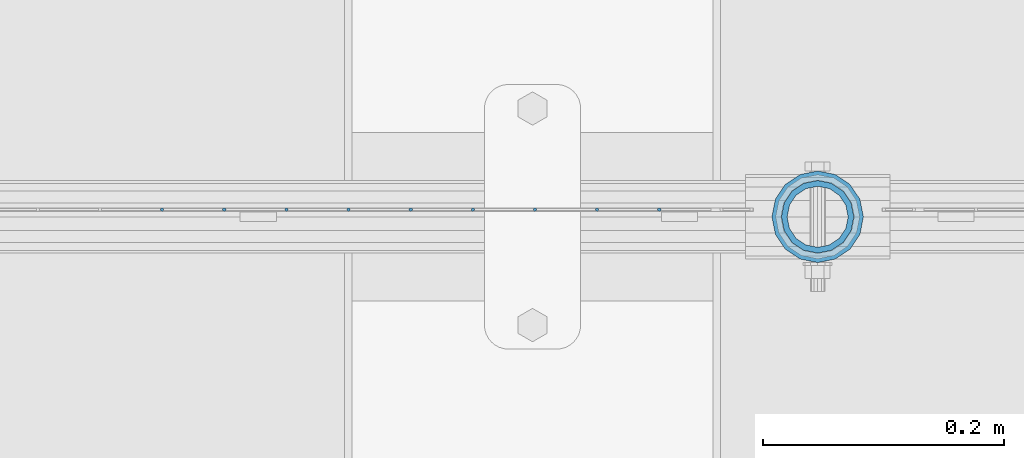
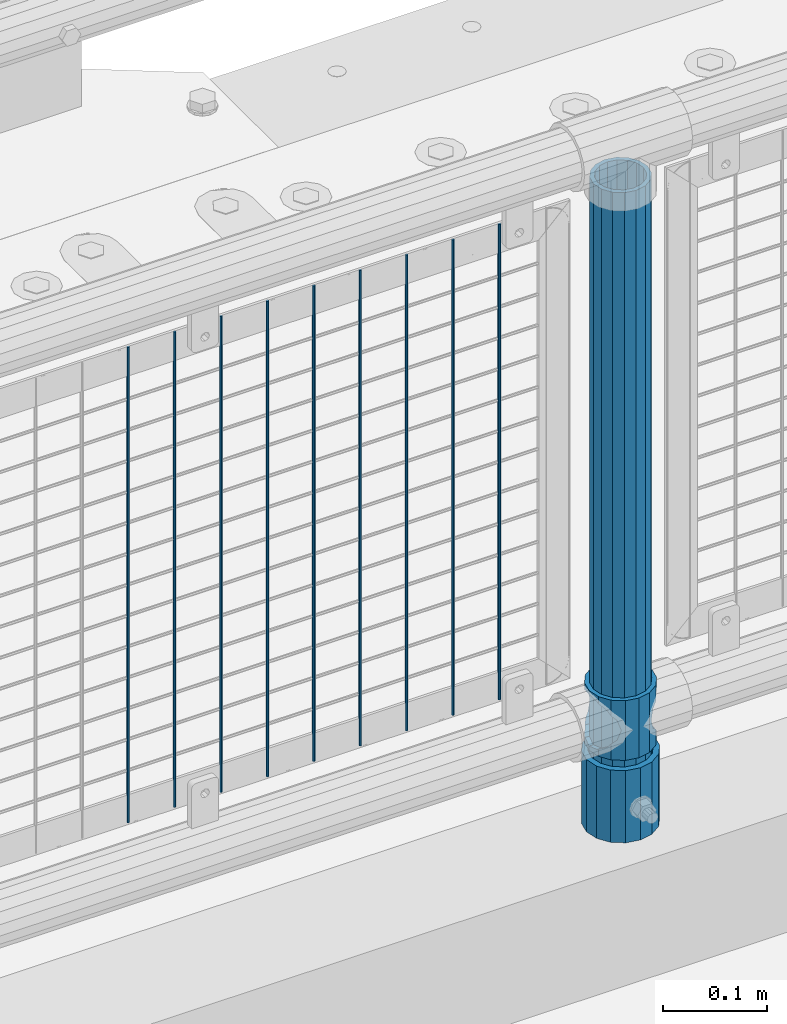
# One storey, part 58 of 193: 12 columns.
"""IFC2X3 building model written with IfcOpenShell, lengths in millimetres."""

import ifcopenshell
import ifcopenshell.guid

model = None  # the IFC model being written
_history = None  # IfcOwnerHistory: only IFC2X3 demands one
_inside = {}  # id of a spatial element -> (the spatial element, [elements in it])
_under = {}  # id of a project, library or spatial element -> (it, [spatial elements below it])
_declared = {}  # id of a project -> (the project, [libraries it declares])
_typed = {}  # id of a type object -> (the type object, [elements of that type])
_made_of = {}  # id of a material, layer set ... -> (it, [elements and type objects made of it])


def new_model(schema):
    """Start an empty IFC model of exactly this schema.

    Asked for "IFC4X3", IfcOpenShell would pick the latest addendum, in which some entities
    have other attributes; the version numbers below select the first issue.
    IFC2X3 requires an IfcOwnerHistory on every rooted entity: one is made here for all.
    """
    global model, _history
    if schema == "IFC4X3":
        model = ifcopenshell.file(schema_version=(4, 3, 0, 0))
    else:
        model = ifcopenshell.file(schema=schema)
    _inside.clear()
    _under.clear()
    _declared.clear()
    _typed.clear()
    _made_of.clear()
    _history = None
    if model.schema == "IFC2X3":
        org = make("IfcOrganization", Name="unknown")
        user = make(
            "IfcPersonAndOrganization",
            ThePerson=make("IfcPerson", FamilyName="unknown"),
            TheOrganization=org,
        )
        app = make(
            "IfcApplication",
            ApplicationDeveloper=org,
            Version="unknown",
            ApplicationFullName="unknown",
            ApplicationIdentifier="unknown",
        )
        _history = make(
            "IfcOwnerHistory",
            OwningUser=user,
            OwningApplication=app,
            ChangeAction="ADDED",
            CreationDate=0,
        )
    return model


def make(cls, **values):
    """One entity of the class cls with the attributes given. An attribute that is None is left unset."""
    return model.create_entity(
        cls, **{name: value for name, value in values.items() if value is not None}
    )


def rooted(cls, **values):
    """An entity with a GlobalId (a new one), such as an element, a storey or a relation."""
    return make(cls, GlobalId=ifcopenshell.guid.new(), OwnerHistory=_history, **values)


def si_unit(unit_type, name, prefix=None):
    """IfcSIUnit, for example si_unit("LENGTHUNIT", "METRE", prefix="MILLI")."""
    return make("IfcSIUnit", UnitType=unit_type, Prefix=prefix, Name=name)


def assignment(units):
    """IfcUnitAssignment: the units of a project."""
    return None if units is None else make("IfcUnitAssignment", Units=units)


def point(xyz):
    """IfcCartesianPoint."""
    return None if xyz is None else make("IfcCartesianPoint", Coordinates=xyz)


def direction(xyz):
    """IfcDirection."""
    return None if xyz is None else make("IfcDirection", DirectionRatios=xyz)


def frame(location, z_axis=None, x_axis=None):
    """IfcAxis2Placement3D, a coordinate frame: its origin and axes. An axis left out is left unset."""
    return make(
        "IfcAxis2Placement3D",
        Location=point(location),
        Axis=direction(z_axis),
        RefDirection=direction(x_axis),
    )


def origin_with_axes():
    """The frame at (0, 0, 0) with the z axis (0, 0, 1) and the x axis (1, 0, 0) written out."""
    return frame((0.0, 0.0, 0.0), z_axis=(0.0, 0.0, 1.0), x_axis=(1.0, 0.0, 0.0))


def place(relative_to, where):
    """IfcLocalPlacement: puts the frame where relative to a parent placement (None: the world)."""
    return make(
        "IfcLocalPlacement", PlacementRelTo=relative_to, RelativePlacement=where
    )


def context(
    kind, dimensions, precision=None, world=None, true_north=None, identifier=None
):
    """IfcGeometricRepresentationContext, for example the 3D "Model" context."""
    return make(
        "IfcGeometricRepresentationContext",
        ContextIdentifier=identifier,
        ContextType=kind,
        CoordinateSpaceDimension=dimensions,
        Precision=precision,
        WorldCoordinateSystem=world,
        TrueNorth=true_north,
    )


def subcontext(parent, identifier, kind, view, scale=None):
    """IfcGeometricRepresentationSubContext, for example "Body" below "Model"."""
    return make(
        "IfcGeometricRepresentationSubContext",
        ContextIdentifier=identifier,
        ContextType=kind,
        ParentContext=parent,
        TargetScale=scale,
        TargetView=view,
    )


def project(units=None, contexts=None):
    """IfcProject with its units and contexts."""
    return rooted(
        "IfcProject",
        Name="project",
        RepresentationContexts=contexts,
        UnitsInContext=assignment(units),
    )


def spatial(cls, under=None, at=None, **own):
    """A site, building, storey or space (cls), placed at a placement, below another one or the project."""
    s = rooted(cls, ObjectPlacement=at, **own)
    if under is not None:
        _under.setdefault(under.id(), (under, []))[1].append(s)
    return s


def faces_of(points, faces, orient=None, outer=None):
    """IfcFace entities. A face is a list of loops; a loop is a list of indices into points, from 0.

    orient and outer hold one flag for each loop. By default every Orientation is true, the
    first loop of a face is its IfcFaceOuterBound and the others are IfcFaceBound.
    """
    made = []
    for i, loops in enumerate(faces):
        bounds = []
        for j, loop in enumerate(loops):
            is_outer = j == 0 if outer is None else outer[i][j]
            bounds.append(
                make(
                    "IfcFaceOuterBound" if is_outer else "IfcFaceBound",
                    Bound=make("IfcPolyLoop", Polygon=[points[k] for k in loop]),
                    Orientation=True if orient is None else orient[i][j],
                )
            )
        made.append(make("IfcFace", Bounds=bounds))
    return made


def faceted_brep(points, faces, orient=None, outer=None, voids=None):
    """IfcFacetedBrep: a solid bounded by flat faces; with voids (closed shells), ...WithVoids."""
    shared = [point(p) for p in points]
    hull = make("IfcClosedShell", CfsFaces=faces_of(shared, faces, orient, outer))
    if voids is None:
        return make("IfcFacetedBrep", Outer=hull)
    return make(
        "IfcFacetedBrepWithVoids",
        Outer=hull,
        Voids=[
            make(cls, CfsFaces=faces_of(shared, fs, o, b)) for cls, fs, o, b in voids
        ],
    )


def shape(context_of_items, identifier, shape_type, items):
    """IfcShapeRepresentation: the items that make up one representation, for example the "Body"."""
    return make(
        "IfcShapeRepresentation",
        ContextOfItems=context_of_items,
        RepresentationIdentifier=identifier,
        RepresentationType=shape_type,
        Items=items,
    )


def material(Name=None, Category=None):
    """IfcMaterial."""
    return make("IfcMaterial", Name=Name, Category=Category)


def made_of(thing, what):
    """Note that an element or type object is made of a material, layer set ...; save() writes the relation."""
    if what is not None:
        _made_of.setdefault(what.id(), (what, []))[1].append(thing)
    return thing


def type_object(cls, material=None, **own):
    """A type object (cls), such as IfcWallType, which elements share."""
    return made_of(rooted(cls, **own), material)


def element(
    cls,
    number,
    at=None,
    inside=None,
    cuts=None,
    type_object=None,
    material=None,
    context=None,
    identifier="Body",
    shape_type=None,
    held_by="IfcProductDefinitionShape",
    body=None,
    shapes=None,
    **own,
):
    """One element of the class cls, such as IfcWall. Its Tag is "e" and its number.

    at: its placement. inside: the storey or other place that contains it. cuts: it is an
    opening in that element (IfcRelVoidsElement). A single representation is given by context,
    identifier, shape_type and body (its items); several are given by shapes. held_by: the class
    of the entity that holds the representations. save() writes the other relations.
    """
    e = rooted(cls, Tag="e%d" % number, ObjectPlacement=at, **own)
    if body is not None:
        shapes = [shape(context, identifier, shape_type, body)]
    if shapes is not None:
        e.Representation = make(held_by, Representations=shapes)
    if inside is not None:
        _inside.setdefault(inside.id(), (inside, []))[1].append(e)
    if cuts is not None:
        rooted(
            "IfcRelVoidsElement", RelatingBuildingElement=cuts, RelatedOpeningElement=e
        )
    if type_object is not None:
        _typed.setdefault(type_object.id(), (type_object, []))[1].append(e)
    return made_of(e, material)


def aggregate(whole, parts):
    """IfcRelAggregates: a whole, such as a stair, and the parts it consists of."""
    return rooted("IfcRelAggregates", RelatingObject=whole, RelatedObjects=parts)


def save(model, path):
    """Write the relations noted so far, then the file.

    IfcRelAggregates (storeys below a building ...), IfcRelContainedInSpatialStructure (elements
    in a storey), IfcRelDefinesByType, IfcRelAssociatesMaterial and IfcRelDeclares: one each for
    every whole, place, type object, material and project.
    """
    for whole, parts in _under.values():
        aggregate(whole, parts)
    for where, things in _inside.values():
        rooted(
            "IfcRelContainedInSpatialStructure",
            RelatedElements=things,
            RelatingStructure=where,
        )
    for kind, things in _typed.values():
        rooted("IfcRelDefinesByType", RelatedObjects=things, RelatingType=kind)
    for what, things in _made_of.values():
        rooted("IfcRelAssociatesMaterial", RelatedObjects=things, RelatingMaterial=what)
    for by, libraries in _declared.values():
        rooted("IfcRelDeclares", RelatingContext=by, RelatedDefinitions=libraries)
    model.write(path)


model = new_model("IFC2X3")

# Units and contexts
model_context = context("Model", 3, precision=1e-05, world=origin_with_axes())
body_context = subcontext(model_context, "Body", "Model", "MODEL_VIEW")
ifc_project = project(units=[si_unit("LENGTHUNIT", "METRE", prefix="MILLI"), si_unit("AREAUNIT", "SQUARE_METRE"), si_unit("VOLUMEUNIT", "CUBIC_METRE"), si_unit("MASSUNIT", "GRAM", prefix="KILO"), si_unit("TIMEUNIT", "SECOND"), si_unit("PLANEANGLEUNIT", "RADIAN"), si_unit("SOLIDANGLEUNIT", "STERADIAN"), si_unit("THERMODYNAMICTEMPERATUREUNIT", "DEGREE_CELSIUS"), si_unit("LUMINOUSINTENSITYUNIT", "LUMEN")], contexts=[model_context])

# Site, building, storey
site_placement = place(None, origin_with_axes())
site = spatial("IfcSite", under=ifc_project, at=site_placement, CompositionType="ELEMENT")
building_placement = place(site_placement, origin_with_axes())
building = spatial("IfcBuilding", under=site, at=building_placement, Name="Standard", CompositionType="ELEMENT")
storey_placement = place(building_placement, origin_with_axes())
storey = spatial("IfcBuildingStorey", under=building, at=storey_placement, Name="Undefined", CompositionType="ELEMENT", Elevation=0.0)

# Columns
ifc_material_1 = material(Name="Misc_Undefined")
column_type_1 = type_object("IfcColumnType", PredefinedType="NOTDEFINED")
column_1_placement = place(storey_placement, frame((-38513.0, 28664.5, 263.020000000001), z_axis=(-1.0, 0.0, 0.0), x_axis=(0.0, 0.0, 1.0)))
element("IfcColumn", 1, at=column_1_placement, inside=storey, type_object=column_type_1, material=ifc_material_1, context=body_context, shape_type="Brep", body=[
    faceted_brep([(56.6106908090114, 21.46069080901, -21.46069080901), (56.6106908090114, 21.46069080901, -27.1226768591041), (61.9623795176744, 13.4513226476338, -32.4743655677703), (63.1897438117172, 11.614442172282, -32.8397438117245), (63.1897438117172, 11.614442172282, -28.0397438117179), (46.7644421722801, 28.0397438117179, -11.614442172282), (46.7644421722801, 28.0397438117179, -20.0882031229849), (51.5310424080006, 24.8548033587067, -24.8548033587067), (35.1500000000015, 30.35, 0.0), (35.1499999999996, 30.3499999999985, -16.6306603983685), (23.5355578277192, 28.0397438117179, -11.614442172282), (23.5355578277192, 28.0397438117179, -20.0882031229849), (13.6893091909879, 21.46069080901, -21.46069080901), (13.6893091909879, 21.46069080901, -27.1226768591041), (18.7689575919987, 24.8548033587067, -24.8548033587067), (7.11025618828211, 11.614442172282, -28.0397438117179), (7.11025618828211, 11.614442172282, -32.8397438117245), (8.33762048232262, 13.4513226476338, -32.4743655677703), (4.79999999999961, 0.0, -30.3499999999985), (4.79999999999961, 0.0, -35.1500000000015), (7.11025618828211, -11.614442172282, -28.0397438117179), (7.11025618828211, -11.614442172282, -32.8397438117172), (13.6893091909879, -21.46069080901, -21.46069080901), (13.6893091909879, -21.46069080901, -27.1226768591114), (8.33762048232484, -13.4513226476338, -32.4743655677703), (23.5355578277191, -28.0397438117179, -11.614442172282), (23.5355578277191, -28.0397438117179, -20.0882031229812), (18.7689575919921, -24.8548033587067, -24.8548033587067), (35.1500000000015, -30.35, 0.0), (35.1499999999996, -30.3499999999985, -16.6306603983721), (46.7644421722801, -28.0397438117179, -11.614442172282), (46.7644421722801, -28.0397438117179, -20.0882031229812), (56.6106908090114, -21.46069080901, -21.46069080901), (56.6106908090114, -21.46069080901, -27.1226768591114), (51.5310424080006, -24.8548033587067, -24.8548033587067), (63.1897438117172, -11.614442172282, -28.0397438117179), (63.1897438117172, -11.614442172282, -32.8397438117172), (61.9623795176767, -13.4513226476338, -32.4743655677703), (65.4999999999997, 0.0, -30.3499999999985), (65.4999999999997, 0.0, -35.1500000000015), (0.0, -28.0397438117179, -11.614442172282), (0.0, -30.3499999999985, 0.0), (0.0, -21.46069080901, -21.46069080901), (0.0, -11.614442172282, -28.0397438117179), (0.0, 0.0, -30.3499999999985), (0.0, 11.614442172282, -28.0397438117179), (0.0, 21.46069080901, -21.46069080901), (0.0, 28.0397438117179, -11.614442172282), (0.0, 30.3499999999985, 0.0), (0.0, 28.0397438117179, 11.614442172282), (23.5355578277192, 28.0397438117179, 11.614442172282), (0.0, 21.46069080901, 21.46069080901), (13.6893091909879, 21.46069080901, 21.46069080901), (0.0, 11.614442172282, 28.0397438117179), (7.11025618828211, 11.614442172282, 28.0397438117179), (0.0, 0.0, 30.3499999999985), (4.79999999999961, 0.0, 30.3499999999985), (0.0, -11.614442172282, 28.0397438117179), (7.11025618828205, -11.614442172282, 28.0397438117179), (0.0, -21.46069080901, 21.46069080901), (13.6893091909879, -21.46069080901, 21.46069080901), (0.0, -28.0397438117179, 11.614442172282), (23.5355578277191, -28.0397438117179, 11.614442172282), (0.0, -32.4743655677703, 13.4513226476338), (0.0, -35.1500000000015, 0.0), (70.2999999999993, -35.1500000000015, 0.0), (70.2999999999993, -32.4743655677703, 13.4513226476338), (0.0, 13.4513226476338, -32.4743655677703), (0.0, 24.8548033587067, -24.8548033587067), (0.0, 0.0, -35.1500000000015), (0.0, -13.4513226476338, -32.4743655677703), (0.0, -24.8548033587067, -24.8548033587067), (0.0, -24.8548033587067, 24.8548033587067), (0.0, -13.4513226476338, 32.4743655677703), (0.0, 0.0, 35.1500000000015), (0.0, 13.4513226476338, 32.4743655677703), (0.0, 24.8548033587067, 24.8548033587067), (0.0, 32.4743655677703, 13.4513226476338), (0.0, 35.1500000000015, 0.0), (0.0, 32.4743655677703, -13.4513226476338), (0.0, -32.4743655677703, -13.4513226476338), (70.2999999999993, 32.4743655677703, 13.4513226476338), (70.2999999999993, 35.1500000000015, 0.0), (70.2999999999993, 32.4743655677703, -13.4513226476338), (70.2999999999993, 24.8548033587067, -24.8548033587067), (70.2999999999993, 13.4513226476338, -32.4743655677703), (70.2999999999993, 0.0, -35.1500000000015), (70.2999999999993, -13.4513226476338, -32.4743655677703), (70.2999999999993, -24.8548033587067, -24.8548033587067), (70.2999999999993, -32.4743655677703, -13.4513226476338), (70.2999999999993, 28.0397438117179, 11.614442172282), (70.2999999999993, 21.46069080901, 21.46069080901), (56.6106908090114, 21.46069080901, 21.46069080901), (46.7644421722801, 28.0397438117179, 11.614442172282), (70.2999999999993, 11.614442172282, 28.0397438117179), (63.1897438117172, 11.614442172282, 28.0397438117179), (70.2999999999993, 0.0, 30.3499999999985), (65.4999999999997, 0.0, 30.3499999999985), (70.2999999999993, -11.614442172282, 28.0397438117179), (63.1897438117172, -11.614442172282, 28.0397438117179), (70.2999999999993, -21.46069080901, 21.46069080901), (56.6106908090114, -21.46069080901, 21.46069080901), (70.2999999999993, -28.0397438117179, 11.614442172282), (46.7644421722801, -28.0397438117179, 11.614442172282), (70.2999999999993, -11.614442172282, -28.0397438117179), (70.2999999999993, 0.0, -30.3499999999985), (70.2999999999993, -21.46069080901, -21.46069080901), (70.2999999999993, -28.0397438117179, -11.614442172282), (70.2999999999993, -30.3499999999985, 0.0), (70.2999999999993, 24.8548033587067, 24.8548033587067), (70.2999999999993, 13.4513226476338, 32.4743655677703), (70.2999999999993, 0.0, 35.1500000000015), (70.2999999999993, -13.4513226476338, 32.4743655677703), (70.2999999999993, -24.8548033587067, 24.8548033587067), (70.2999999999993, 30.3499999999985, 0.0), (70.2999999999993, 28.0397438117179, -11.614442172282), (70.2999999999993, 21.46069080901, -21.46069080901), (70.2999999999993, 11.614442172282, -28.0397438117179), (61.9623795176742, 13.4513226476338, 32.4743655677703), (51.5310424080006, 24.8548033587067, 24.8548033587067), (56.6106908090114, 21.46069080901, 27.1226768591077), (65.4999999999997, 0.0, 35.1500000000015), (63.1897438117172, 11.614442172282, 32.8397438117136), (63.1897438117172, -11.614442172282, 32.8397438117136), (61.9623795176767, -13.4513226476338, 32.4743655677703), (56.6106908090114, -21.46069080901, 27.1226768591041), (51.5310424080006, -24.8548033587067, 24.8548033587067), (18.7689575919921, -24.8548033587067, 24.8548033587067), (46.7644421722801, -28.0397438117179, 20.0882031229812), (35.1499999999996, -30.3499999999985, 16.6306603983685), (23.5355578277191, -28.0397438117179, 20.0882031229812), (8.33762048232512, -13.4513226476338, 32.4743655677703), (13.6893091909879, -21.46069080901, 27.1226768591041), (4.79999999999961, 0.0, 35.1500000000015), (7.11025618828205, -11.614442172282, 32.8397438117136), (7.11025618828211, 11.614442172282, 32.8397438117136), (8.3376204823229, 13.4513226476338, 32.4743655677703), (13.6893091909879, 21.46069080901, 27.1226768591077), (18.7689575919987, 24.8548033587067, 24.8548033587067), (23.5355578277192, 28.0397438117179, 20.0882031229739), (35.1499999999996, 30.3499999999985, 16.6306603983576), (46.7644421722801, 28.0397438117179, 20.0882031229739)], [[[0, 1, 2, 3, 4]], [[5, 6, 7, 1, 0]], [[8, 9, 6, 5]], [[10, 11, 9, 8]], [[12, 13, 14, 11, 10]], [[15, 16, 17, 13, 12]], [[18, 19, 16, 15]], [[20, 21, 19, 18]], [[22, 23, 24, 21, 20]], [[25, 26, 27, 23, 22]], [[28, 29, 26, 25]], [[30, 31, 29, 28]], [[32, 33, 34, 31, 30]], [[35, 36, 37, 33, 32]], [[38, 39, 36, 35]], [[4, 3, 39, 38]], [[40, 41, 28, 25]], [[42, 40, 25, 22]], [[43, 42, 22, 20]], [[44, 43, 20, 18]], [[45, 44, 18, 15]], [[46, 45, 15, 12]], [[47, 46, 12, 10]], [[48, 47, 10, 8]], [[49, 48, 8, 50]], [[51, 49, 50, 52]], [[53, 51, 52, 54]], [[55, 53, 54, 56]], [[57, 55, 56, 58]], [[59, 57, 58, 60]], [[61, 59, 60, 62]], [[41, 61, 62, 28]], [[63, 64, 65, 66]], [[17, 67, 68, 14, 13]], [[19, 69, 67, 17, 16]], [[70, 69, 19, 21, 24]], [[71, 70, 24, 23, 27]], [[63, 72, 73, 74, 75, 76, 77, 78, 79, 68, 67, 69, 70, 71, 80, 64], [40, 42, 43, 44, 45, 46, 47, 48, 49, 51, 53, 55, 57, 59, 61, 41]], [[78, 77, 81, 82]], [[79, 78, 82, 83]], [[14, 68, 79, 83, 84, 7, 6, 9, 11]], [[84, 85, 2, 1, 7]], [[85, 86, 39, 3, 2]], [[37, 87, 88, 34, 33]], [[39, 86, 87, 37, 36]], [[34, 88, 89, 80, 71, 27, 26, 29, 31]], [[64, 80, 89, 65]], [[90, 91, 92, 93]], [[91, 94, 95, 92]], [[94, 96, 97, 95]], [[96, 98, 99, 97]], [[98, 100, 101, 99]], [[100, 102, 103, 101]], [[104, 105, 38, 35]], [[106, 104, 35, 32]], [[107, 106, 32, 30]], [[108, 107, 30, 28]], [[102, 108, 28, 103]], [[88, 87, 86, 85, 84, 83, 82, 81, 109, 110, 111, 112, 113, 66, 65, 89], [100, 98, 96, 94, 91, 90, 114, 115, 116, 117, 105, 104, 106, 107, 108, 102]], [[118, 110, 109, 119, 120]], [[121, 111, 110, 118, 122]], [[112, 111, 121, 123, 124]], [[113, 112, 124, 125, 126]], [[127, 72, 63, 66, 113, 126, 128, 129, 130]], [[131, 73, 72, 127, 132]], [[133, 74, 73, 131, 134]], [[75, 74, 133, 135, 136]], [[76, 75, 136, 137, 138]], [[119, 109, 81, 77, 76, 138, 139, 140, 141]], [[92, 120, 119, 141, 93]], [[95, 122, 118, 120, 92]], [[97, 121, 122, 95]], [[99, 123, 121, 97]], [[101, 125, 124, 123, 99]], [[103, 128, 126, 125, 101]], [[28, 129, 128, 103]], [[62, 130, 129, 28]], [[60, 132, 127, 130, 62]], [[58, 134, 131, 132, 60]], [[56, 133, 134, 58]], [[54, 135, 133, 56]], [[52, 137, 136, 135, 54]], [[50, 139, 138, 137, 52]], [[8, 140, 139, 50]], [[93, 141, 140, 8]], [[114, 90, 93, 8]], [[115, 114, 8, 5]], [[116, 115, 5, 0]], [[117, 116, 0, 4]], [[105, 117, 4, 38]]]),
])
ifc_material_2 = material()
column_type_2 = type_object("IfcColumnType", PredefinedType="NOTDEFINED")
column_2_placement = place(storey_placement, frame((-38513.0, 28664.5, 168.02), z_axis=(-1.0, 0.0, 0.0), x_axis=(0.0, 0.0, 1.0)))
element("IfcColumn", 2, at=column_2_placement, inside=storey, type_object=column_type_2, material=ifc_material_2, context=body_context, shape_type="Brep", body=[
    faceted_brep([(0.0, -25.3499999999985, 0.0), (0.0, -23.4203461491597, 9.70102501045403), (760.0, -23.4203461491597, 9.70102501045403), (760.0, -25.3499999999985, 0.0), (0.0, -17.9251569030785, 17.9251569030785), (760.0, -17.9251569030785, 17.9251569030785), (0.0, -9.70102501045403, 23.4203461491597), (760.0, -9.70102501045403, 23.4203461491597), (0.0, 0.0, 25.3499999999985), (760.0, 0.0, 25.3499999999985), (0.0, 9.70102501045403, 23.4203461491597), (760.0, 9.70102501045403, 23.4203461491597), (0.0, 17.9251569030785, 17.9251569030785), (760.0, 17.9251569030785, 17.9251569030785), (0.0, 23.4203461491597, 9.70102501045403), (760.0, 23.4203461491597, 9.70102501045403), (0.0, 25.3499999999985, 0.0), (760.0, 25.3499999999985, 0.0), (0.0, 23.4203461491597, -9.70102501045403), (760.0, 23.4203461491597, -9.70102501045403), (0.0, 17.9251569030785, -17.9251569030785), (760.0, 17.9251569030785, -17.9251569030785), (0.0, 9.70102501045403, -23.4203461491597), (760.0, 9.70102501045403, -23.4203461491597), (0.0, 0.0, -25.3499999999985), (760.0, 0.0, -25.3499999999985), (0.0, -9.70102501045403, -23.4203461491597), (760.0, -9.70102501045403, -23.4203461491597), (0.0, -17.9251569030785, -17.9251569030785), (760.0, -17.9251569030785, -17.9251569030785), (0.0, -23.4203461491597, -9.70102501045403), (760.0, -23.4203461491597, -9.70102501045403), (0.0, -30.1500000000015, 0.0), (0.0, -27.8549679052157, -11.5379054858058), (760.0, -27.8549679052157, -11.5379054858058), (760.0, -30.1500000000015, 0.0), (0.0, -21.3192694527752, -21.3192694527752), (760.0, -21.3192694527752, -21.3192694527752), (0.0, -11.5379054858058, -27.8549679052157), (760.0, -11.5379054858058, -27.8549679052157), (0.0, 0.0, -30.1500000000015), (760.0, 0.0, -30.1500000000015), (0.0, 11.5379054858058, -27.8549679052157), (760.0, 11.5379054858058, -27.8549679052157), (0.0, 21.3192694527752, -21.3192694527752), (760.0, 21.3192694527752, -21.3192694527752), (0.0, 27.8549679052157, -11.5379054858058), (760.0, 27.8549679052157, -11.5379054858058), (0.0, 30.1500000000015, 0.0), (760.0, 30.1500000000015, 0.0), (0.0, 27.8549679052157, 11.5379054858058), (760.0, 27.8549679052157, 11.5379054858058), (0.0, 21.3192694527752, 21.3192694527752), (760.0, 21.3192694527752, 21.3192694527752), (0.0, 11.5379054858058, 27.8549679052157), (760.0, 11.5379054858058, 27.8549679052157), (0.0, 0.0, 30.1500000000015), (760.0, 0.0, 30.1500000000015), (0.0, -11.5379054858058, 27.8549679052157), (760.0, -11.5379054858058, 27.8549679052157), (0.0, -21.3192694527752, 21.3192694527752), (760.0, -21.3192694527752, 21.3192694527752), (0.0, -27.8549679052157, 11.5379054858058), (760.0, -27.8549679052157, 11.5379054858058)], [[[0, 1, 2, 3]], [[1, 4, 5, 2]], [[4, 6, 7, 5]], [[6, 8, 9, 7]], [[8, 10, 11, 9]], [[10, 12, 13, 11]], [[12, 14, 15, 13]], [[14, 16, 17, 15]], [[16, 18, 19, 17]], [[18, 20, 21, 19]], [[20, 22, 23, 21]], [[22, 24, 25, 23]], [[24, 26, 27, 25]], [[26, 28, 29, 27]], [[28, 30, 31, 29]], [[30, 0, 3, 31]], [[32, 33, 34, 35]], [[33, 36, 37, 34]], [[36, 38, 39, 37]], [[38, 40, 41, 39]], [[40, 42, 43, 41]], [[42, 44, 45, 43]], [[44, 46, 47, 45]], [[46, 48, 49, 47]], [[48, 50, 51, 49]], [[50, 52, 53, 51]], [[52, 54, 55, 53]], [[54, 56, 57, 55]], [[56, 58, 59, 57]], [[58, 60, 61, 59]], [[60, 62, 63, 61]], [[62, 32, 35, 63]], [[37, 39, 41, 43, 45, 47, 49, 51, 53, 55, 57, 59, 61, 63, 35, 34], [5, 7, 9, 11, 13, 15, 17, 19, 21, 23, 25, 27, 29, 31, 3, 2]], [[62, 60, 58, 56, 54, 52, 50, 48, 46, 44, 42, 40, 38, 36, 33, 32], [30, 28, 26, 24, 22, 20, 18, 16, 14, 12, 10, 8, 6, 4, 1, 0]]]),
])
column_type_3 = type_object("IfcColumnType", PredefinedType="NOTDEFINED")
column_3_placement = place(storey_placement, frame((-38513.0, 28664.5, 168.02), z_axis=(0.0, 1.0, 0.0), x_axis=(0.0, 0.0, 1.0)))
element("IfcColumn", 3, at=column_3_placement, inside=storey, type_object=column_type_3, material=ifc_material_2, context=body_context, shape_type="Brep", body=[
    faceted_brep([(0.0, -31.75, 0.0), (0.0, -29.3331751572332, 12.1501989775934), (85.0, -29.3331751572332, 12.1501989775934), (85.0, -31.75, 0.0), (0.0, -22.4506403026717, 22.4506403026717), (85.0, -22.4506403026717, 22.4506403026717), (0.0, -12.1501989775934, 29.3331751572332), (85.0, -12.1501989775934, 29.3331751572332), (0.0, 0.0, 31.75), (85.0, 0.0, 31.75), (0.0, 12.1501989775934, 29.3331751572332), (85.0, 12.1501989775934, 29.3331751572332), (0.0, 22.4506403026717, 22.4506403026717), (85.0, 22.4506403026717, 22.4506403026717), (0.0, 29.3331751572332, 12.1501989775934), (85.0, 29.3331751572332, 12.1501989775934), (0.0, 31.75, 0.0), (85.0, 31.75, 0.0), (0.0, 29.3331751572332, -12.1501989775934), (85.0, 29.3331751572332, -12.1501989775934), (0.0, 22.4506403026717, -22.4506403026717), (85.0, 22.4506403026717, -22.4506403026717), (0.0, 12.1501989775934, -29.3331751572332), (85.0, 12.1501989775934, -29.3331751572332), (0.0, 0.0, -31.75), (85.0, 0.0, -31.75), (0.0, -12.1501989775934, -29.3331751572332), (85.0, -12.1501989775934, -29.3331751572332), (0.0, -22.4506403026717, -22.4506403026717), (85.0, -22.4506403026717, -22.4506403026717), (0.0, -29.3331751572332, -12.1501989775934), (85.0, -29.3331751572332, -12.1501989775934), (0.0, -38.0499999999993, 0.0), (0.0, -35.1536162120537, -14.5611046014928), (85.0, -35.1536162120537, -14.5611046014928), (85.0, -38.0499999999993, 0.0), (0.0, -26.9054130241493, -26.9054130241493), (85.0, -26.9054130241493, -26.9054130241493), (0.0, -14.5611046014928, -35.1536162120537), (85.0, -14.5611046014928, -35.1536162120537), (0.0, 0.0, -38.0499999999993), (85.0, 0.0, -38.0499999999993), (0.0, 14.5611046014928, -35.1536162120537), (85.0, 14.5611046014928, -35.1536162120537), (0.0, 26.9054130241493, -26.9054130241493), (85.0, 26.9054130241493, -26.9054130241493), (0.0, 35.1536162120537, -14.5611046014928), (85.0, 35.1536162120537, -14.5611046014928), (0.0, 38.0499999999993, 0.0), (85.0, 38.0499999999993, 0.0), (0.0, 35.1536162120537, 14.5611046014928), (85.0, 35.1536162120537, 14.5611046014928), (0.0, 26.9054130241493, 26.9054130241493), (85.0, 26.9054130241493, 26.9054130241493), (0.0, 14.5611046014928, 35.1536162120537), (85.0, 14.5611046014928, 35.1536162120537), (0.0, 0.0, 38.0499999999993), (85.0, 0.0, 38.0499999999993), (0.0, -14.5611046014928, 35.1536162120537), (85.0, -14.5611046014928, 35.1536162120537), (0.0, -26.9054130241493, 26.9054130241493), (85.0, -26.9054130241493, 26.9054130241493), (0.0, -35.1536162120537, 14.5611046014928), (85.0, -35.1536162120537, 14.5611046014928)], [[[0, 1, 2, 3]], [[1, 4, 5, 2]], [[4, 6, 7, 5]], [[6, 8, 9, 7]], [[8, 10, 11, 9]], [[10, 12, 13, 11]], [[12, 14, 15, 13]], [[14, 16, 17, 15]], [[16, 18, 19, 17]], [[18, 20, 21, 19]], [[20, 22, 23, 21]], [[22, 24, 25, 23]], [[24, 26, 27, 25]], [[26, 28, 29, 27]], [[28, 30, 31, 29]], [[30, 0, 3, 31]], [[32, 33, 34, 35]], [[33, 36, 37, 34]], [[36, 38, 39, 37]], [[38, 40, 41, 39]], [[40, 42, 43, 41]], [[42, 44, 45, 43]], [[44, 46, 47, 45]], [[46, 48, 49, 47]], [[48, 50, 51, 49]], [[50, 52, 53, 51]], [[52, 54, 55, 53]], [[54, 56, 57, 55]], [[56, 58, 59, 57]], [[58, 60, 61, 59]], [[60, 62, 63, 61]], [[62, 32, 35, 63]], [[37, 39, 41, 43, 45, 47, 49, 51, 53, 55, 57, 59, 61, 63, 35, 34], [5, 7, 9, 11, 13, 15, 17, 19, 21, 23, 25, 27, 29, 31, 3, 2]], [[62, 60, 58, 56, 54, 52, 50, 48, 46, 44, 42, 40, 38, 36, 33, 32], [30, 28, 26, 24, 22, 20, 18, 16, 14, 12, 10, 8, 6, 4, 1, 0]]]),
])
column_type_4 = type_object("IfcColumnType", Name="D3", PredefinedType="NOTDEFINED")
for number, where, z_axis, x_axis in (
    (4, (-38644.66, 28670.5, 353.02), (-1.0, 0.0, 0.0), (0.0, 0.0, 1.0)),
    (5, (-38696.315, 28670.5, 353.02), (-1.0, 0.0, 0.0), (0.0, 0.0, 1.0)),
    (6, (-38747.97, 28670.5, 353.02), (-1.0, 0.0, 0.0), (0.0, 0.0, 1.0)),
    (7, (-38799.625, 28670.5, 353.02), (-1.0, 0.0, 0.0), (0.0, 0.0, 1.0)),
    (8, (-38851.28, 28670.5, 353.02), (-1.0, 0.0, 0.0), (0.0, 0.0, 1.0)),
    (9, (-38902.935, 28670.5, 353.02), (-1.0, 0.0, 0.0), (0.0, 0.0, 1.0)),
    (10, (-38954.59, 28670.5, 353.02), (-1.0, 0.0, 0.0), (0.0, 0.0, 1.0)),
    (11, (-39006.245, 28670.5, 353.02), (-1.0, 0.0, 0.0), (0.0, 0.0, 1.0)),
    (12, (-39057.9, 28670.5, 353.02), (-1.0, 0.0, 0.0), (0.0, 0.0, 1.0)),
):
    element("IfcColumn", number, at=place(storey_placement, frame(where, z_axis=z_axis, x_axis=x_axis)), inside=storey, type_object=column_type_4, material=ifc_material_1, ObjectType="D3", context=body_context, shape_type="Brep", body=[
        faceted_brep([(0.0, -1.49999999999636, 3.63797880709171e-12), (0.0, -0.75, -1.29903810567669), (560.0, -0.75, -1.29903810567703), (560.0, -1.5, 0.0), (0.0, 0.75, -1.29903810567669), (560.0, 0.75, -1.29903810567703), (0.0, 1.50000000000364, 7.27595761418343e-12), (560.0, 1.5, 0.0), (0.0, 0.75, 1.29903810567669), (560.0, 0.75, 1.29903810567703), (0.0, -0.75, 1.29903810567669), (560.0, -0.75, 1.29903810567703)], [[[0, 1, 2, 3]], [[1, 4, 5, 2]], [[4, 6, 7, 5]], [[6, 8, 9, 7]], [[8, 10, 11, 9]], [[10, 0, 3, 11]], [[5, 7, 9, 11, 3, 2]], [[10, 8, 6, 4, 1, 0]]]),
    ])

save(model, "model.ifc")
